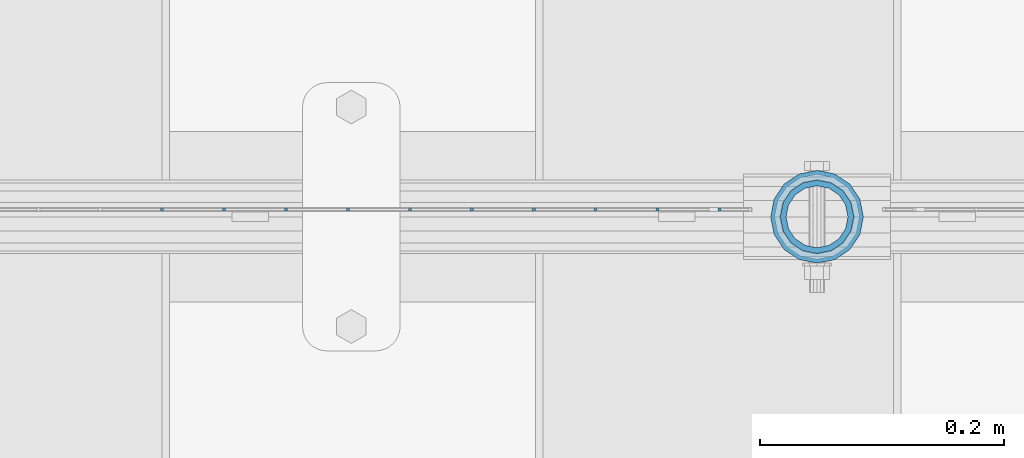
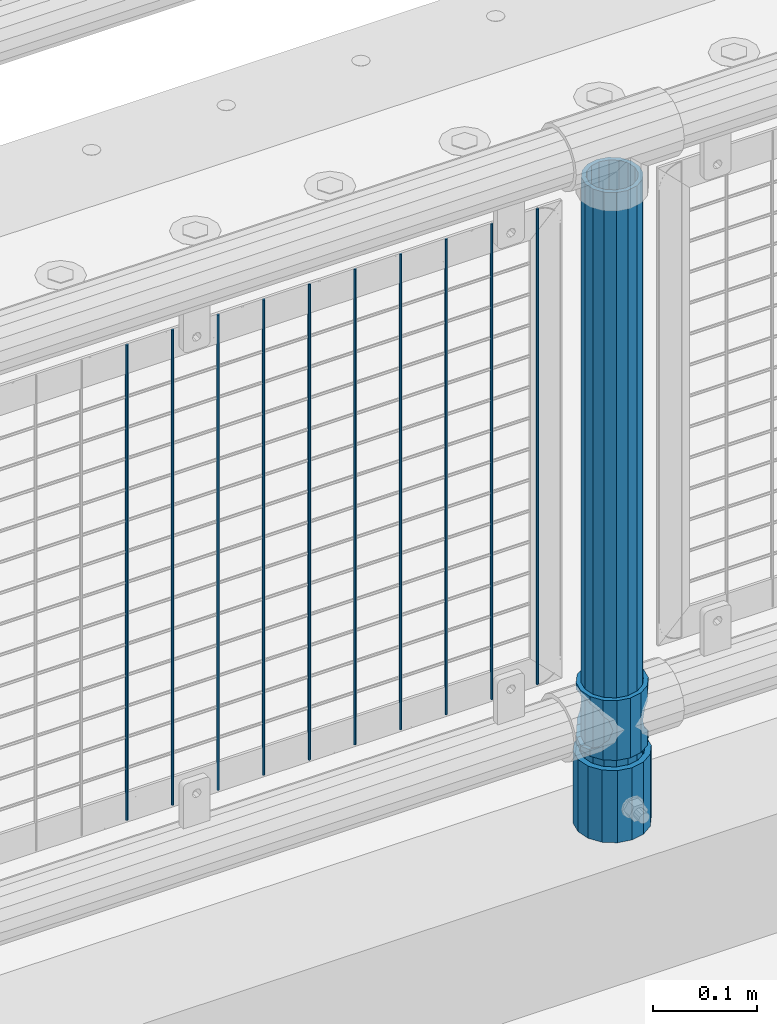
# One storey, part 103 of 270: 13 columns.
"""IFC2X3 building model written with IfcOpenShell, lengths in millimetres."""

from ifc_helpers import new_model, si_unit, frame, origin_with_axes, place, context, subcontext, project, spatial, faceted_brep, material, type_object, element, save


model = new_model("IFC2X3")

# Units and contexts
model_context = context("Model", 3, precision=1e-05, world=origin_with_axes())
body_context = subcontext(model_context, "Body", "Model", "MODEL_VIEW")
ifc_project = project(units=[si_unit("LENGTHUNIT", "METRE", prefix="MILLI"), si_unit("AREAUNIT", "SQUARE_METRE"), si_unit("VOLUMEUNIT", "CUBIC_METRE"), si_unit("MASSUNIT", "GRAM", prefix="KILO"), si_unit("TIMEUNIT", "SECOND"), si_unit("PLANEANGLEUNIT", "RADIAN"), si_unit("SOLIDANGLEUNIT", "STERADIAN"), si_unit("THERMODYNAMICTEMPERATUREUNIT", "DEGREE_CELSIUS"), si_unit("LUMINOUSINTENSITYUNIT", "LUMEN")], contexts=[model_context])

# Site, building, storey
site_placement = place(None, origin_with_axes())
site = spatial("IfcSite", under=ifc_project, at=site_placement, CompositionType="ELEMENT")
building_placement = place(site_placement, origin_with_axes())
building = spatial("IfcBuilding", under=site, at=building_placement, Name="Standard", CompositionType="ELEMENT")
storey_placement = place(building_placement, origin_with_axes())
storey = spatial("IfcBuildingStorey", under=building, at=storey_placement, Name="Undefined", CompositionType="ELEMENT", Elevation=0.0)

# Columns
ifc_material_1 = material()
column_type_1 = type_object("IfcColumnType", PredefinedType="NOTDEFINED")
column_1_placement = place(storey_placement, frame((16950.9999998042, -16335.5, 168.019999999998), z_axis=(-1.0, 0.0, 0.0), x_axis=(0.0, 0.0, 1.0)))
element("IfcColumn", 1, at=column_1_placement, inside=storey, type_object=column_type_1, material=ifc_material_1, context=body_context, shape_type="Brep", body=[
    faceted_brep([(0.0, -25.3500000000004, 0.0), (0.0, -23.4203461491616, 9.70102501045403), (760.0, -23.4203461491616, 9.70102501045403), (760.0, -25.3500000000004, 0.0), (0.0, -17.9251569030785, 17.9251569030785), (760.0, -17.9251569030785, 17.9251569030785), (0.0, -9.70102501045585, 23.4203461491597), (760.0, -9.70102501045585, 23.4203461491597), (0.0, 0.0, 25.3499999999985), (760.0, 0.0, 25.3499999999985), (0.0, 9.70102501045585, 23.4203461491597), (760.0, 9.70102501045585, 23.4203461491597), (0.0, 17.9251569030785, 17.9251569030785), (760.0, 17.9251569030785, 17.9251569030785), (0.0, 23.4203461491616, 9.70102501045403), (760.0, 23.4203461491616, 9.70102501045403), (0.0, 25.3500000000004, 0.0), (760.0, 25.3500000000004, 0.0), (0.0, 23.4203461491616, -9.70102501045403), (760.0, 23.4203461491616, -9.70102501045403), (0.0, 17.9251569030785, -17.9251569030785), (760.0, 17.9251569030785, -17.9251569030785), (0.0, 9.70102501045585, -23.4203461491597), (760.0, 9.70102501045585, -23.4203461491597), (0.0, 0.0, -25.3499999999985), (760.0, 0.0, -25.3499999999985), (0.0, -9.70102501045585, -23.4203461491597), (760.0, -9.70102501045585, -23.4203461491597), (0.0, -17.9251569030785, -17.9251569030785), (760.0, -17.9251569030785, -17.9251569030785), (0.0, -23.4203461491616, -9.70102501045403), (760.0, -23.4203461491616, -9.70102501045403), (0.0, -30.1499999999996, 0.0), (0.0, -27.8549679052157, -11.5379054858058), (760.0, -27.8549679052157, -11.5379054858058), (760.0, -30.1499999999996, 0.0), (0.0, -21.3192694527752, -21.3192694527752), (760.0, -21.3192694527752, -21.3192694527752), (0.0, -11.5379054858076, -27.8549679052157), (760.0, -11.5379054858076, -27.8549679052157), (0.0, 0.0, -30.1500000000015), (760.0, 0.0, -30.1500000000015), (0.0, 11.5379054858076, -27.8549679052157), (760.0, 11.5379054858076, -27.8549679052157), (0.0, 21.3192694527752, -21.3192694527752), (760.0, 21.3192694527752, -21.3192694527752), (0.0, 27.8549679052157, -11.5379054858058), (760.0, 27.8549679052157, -11.5379054858058), (0.0, 30.1499999999996, 0.0), (760.0, 30.1499999999996, 0.0), (0.0, 27.8549679052157, 11.5379054858058), (760.0, 27.8549679052157, 11.5379054858058), (0.0, 21.3192694527752, 21.3192694527752), (760.0, 21.3192694527752, 21.3192694527752), (0.0, 11.5379054858076, 27.8549679052157), (760.0, 11.5379054858076, 27.8549679052157), (0.0, 0.0, 30.1500000000015), (760.0, 0.0, 30.1500000000015), (0.0, -11.5379054858076, 27.8549679052157), (760.0, -11.5379054858076, 27.8549679052157), (0.0, -21.3192694527752, 21.3192694527752), (760.0, -21.3192694527752, 21.3192694527752), (0.0, -27.8549679052157, 11.5379054858058), (760.0, -27.8549679052157, 11.5379054858058)], [[[0, 1, 2, 3]], [[1, 4, 5, 2]], [[4, 6, 7, 5]], [[6, 8, 9, 7]], [[8, 10, 11, 9]], [[10, 12, 13, 11]], [[12, 14, 15, 13]], [[14, 16, 17, 15]], [[16, 18, 19, 17]], [[18, 20, 21, 19]], [[20, 22, 23, 21]], [[22, 24, 25, 23]], [[24, 26, 27, 25]], [[26, 28, 29, 27]], [[28, 30, 31, 29]], [[30, 0, 3, 31]], [[32, 33, 34, 35]], [[33, 36, 37, 34]], [[36, 38, 39, 37]], [[38, 40, 41, 39]], [[40, 42, 43, 41]], [[42, 44, 45, 43]], [[44, 46, 47, 45]], [[46, 48, 49, 47]], [[48, 50, 51, 49]], [[50, 52, 53, 51]], [[52, 54, 55, 53]], [[54, 56, 57, 55]], [[56, 58, 59, 57]], [[58, 60, 61, 59]], [[60, 62, 63, 61]], [[62, 32, 35, 63]], [[37, 39, 41, 43, 45, 47, 49, 51, 53, 55, 57, 59, 61, 63, 35, 34], [5, 7, 9, 11, 13, 15, 17, 19, 21, 23, 25, 27, 29, 31, 3, 2]], [[62, 60, 58, 56, 54, 52, 50, 48, 46, 44, 42, 40, 38, 36, 33, 32], [30, 28, 26, 24, 22, 20, 18, 16, 14, 12, 10, 8, 6, 4, 1, 0]]]),
])
column_type_2 = type_object("IfcColumnType", PredefinedType="NOTDEFINED")
column_2_placement = place(storey_placement, frame((16950.9999998042, -16335.5, 168.019999999998), z_axis=(0.0, 1.0, 0.0), x_axis=(0.0, 0.0, 1.0)))
element("IfcColumn", 2, at=column_2_placement, inside=storey, type_object=column_type_2, material=ifc_material_1, context=body_context, shape_type="Brep", body=[
    faceted_brep([(0.0, -31.75, 0.0), (0.0, -29.3331751572332, 12.1501989775916), (85.0, -29.3331751572332, 12.1501989775916), (85.0, -31.75, 0.0), (0.0, -22.4506403026717, 22.4506403026735), (85.0, -22.4506403026717, 22.4506403026735), (0.0, -12.1501989775934, 29.3331751572332), (85.0, -12.1501989775934, 29.3331751572332), (0.0, 0.0, 31.75), (85.0, 0.0, 31.75), (0.0, 12.1501989775934, 29.3331751572332), (85.0, 12.1501989775934, 29.3331751572332), (0.0, 22.4506403026717, 22.4506403026735), (85.0, 22.4506403026717, 22.4506403026735), (0.0, 29.3331751572332, 12.1501989775916), (85.0, 29.3331751572332, 12.1501989775916), (0.0, 31.75, 0.0), (85.0, 31.75, 0.0), (0.0, 29.3331751572332, -12.1501989775916), (85.0, 29.3331751572332, -12.1501989775916), (0.0, 22.4506403026717, -22.4506403026735), (85.0, 22.4506403026717, -22.4506403026735), (0.0, 12.1501989775934, -29.3331751572332), (85.0, 12.1501989775934, -29.3331751572332), (0.0, 0.0, -31.75), (85.0, 0.0, -31.75), (0.0, -12.1501989775934, -29.3331751572332), (85.0, -12.1501989775934, -29.3331751572332), (0.0, -22.4506403026717, -22.4506403026735), (85.0, -22.4506403026717, -22.4506403026735), (0.0, -29.3331751572332, -12.1501989775916), (85.0, -29.3331751572332, -12.1501989775916), (0.0, -38.0499999999993, 0.0), (0.0, -35.1536162120537, -14.561104601491), (85.0, -35.1536162120537, -14.561104601491), (85.0, -38.0499999999993, 0.0), (0.0, -26.9054130241493, -26.9054130241475), (85.0, -26.9054130241493, -26.9054130241475), (0.0, -14.5611046014928, -35.1536162120537), (85.0, -14.5611046014928, -35.1536162120537), (0.0, 0.0, -38.0499999999993), (85.0, 0.0, -38.0499999999993), (0.0, 14.5611046014928, -35.1536162120537), (85.0, 14.5611046014928, -35.1536162120537), (0.0, 26.9054130241493, -26.9054130241475), (85.0, 26.9054130241493, -26.9054130241475), (0.0, 35.1536162120537, -14.561104601491), (85.0, 35.1536162120537, -14.561104601491), (0.0, 38.0499999999993, 0.0), (85.0, 38.0499999999993, 0.0), (0.0, 35.1536162120537, 14.561104601491), (85.0, 35.1536162120537, 14.561104601491), (0.0, 26.9054130241493, 26.9054130241475), (85.0, 26.9054130241493, 26.9054130241475), (0.0, 14.5611046014928, 35.1536162120537), (85.0, 14.5611046014928, 35.1536162120537), (0.0, 0.0, 38.0499999999993), (85.0, 0.0, 38.0499999999993), (0.0, -14.5611046014928, 35.1536162120537), (85.0, -14.5611046014928, 35.1536162120537), (0.0, -26.9054130241493, 26.9054130241475), (85.0, -26.9054130241493, 26.9054130241475), (0.0, -35.1536162120537, 14.561104601491), (85.0, -35.1536162120537, 14.561104601491)], [[[0, 1, 2, 3]], [[1, 4, 5, 2]], [[4, 6, 7, 5]], [[6, 8, 9, 7]], [[8, 10, 11, 9]], [[10, 12, 13, 11]], [[12, 14, 15, 13]], [[14, 16, 17, 15]], [[16, 18, 19, 17]], [[18, 20, 21, 19]], [[20, 22, 23, 21]], [[22, 24, 25, 23]], [[24, 26, 27, 25]], [[26, 28, 29, 27]], [[28, 30, 31, 29]], [[30, 0, 3, 31]], [[32, 33, 34, 35]], [[33, 36, 37, 34]], [[36, 38, 39, 37]], [[38, 40, 41, 39]], [[40, 42, 43, 41]], [[42, 44, 45, 43]], [[44, 46, 47, 45]], [[46, 48, 49, 47]], [[48, 50, 51, 49]], [[50, 52, 53, 51]], [[52, 54, 55, 53]], [[54, 56, 57, 55]], [[56, 58, 59, 57]], [[58, 60, 61, 59]], [[60, 62, 63, 61]], [[62, 32, 35, 63]], [[37, 39, 41, 43, 45, 47, 49, 51, 53, 55, 57, 59, 61, 63, 35, 34], [5, 7, 9, 11, 13, 15, 17, 19, 21, 23, 25, 27, 29, 31, 3, 2]], [[62, 60, 58, 56, 54, 52, 50, 48, 46, 44, 42, 40, 38, 36, 33, 32], [30, 28, 26, 24, 22, 20, 18, 16, 14, 12, 10, 8, 6, 4, 1, 0]]]),
])
ifc_material_2 = material(Name="Misc_Undefined")
column_type_3 = type_object("IfcColumnType", PredefinedType="NOTDEFINED")
column_3_placement = place(storey_placement, frame((16951.0, -16335.5, 263.02), z_axis=(-1.0, 0.0, 0.0), x_axis=(0.0, 0.0, 1.0)))
element("IfcColumn", 3, at=column_3_placement, inside=storey, type_object=column_type_3, material=ifc_material_2, context=body_context, shape_type="Brep", body=[
    faceted_brep([(63.1897438117183, 11.6144421722802, -32.8397438117208), (63.1897438117183, 11.6144421722802, -28.0397438117179), (56.6106908090125, 21.4606908090118, -21.46069080901), (56.6106908090125, 21.4606908090118, -27.1226768591005), (61.9623795176767, 13.4513226476338, -32.4743655677703), (46.7644421722812, 28.0397438117179, -11.614442172282), (46.7644421722812, 28.0397438117179, -20.0882031229812), (51.5310424080071, 24.8548033587067, -24.8548033587067), (35.1500000000015, 30.35, 0.0), (35.1500000000008, 30.3500000000004, -16.6306603983612), (23.5355578277203, 28.0397438117179, -11.614442172282), (23.5355578277203, 28.0397438117179, -20.0882031229812), (18.7689575919954, 24.8548033587067, -24.8548033587067), (13.689309190989, 21.4606908090118, -21.46069080901), (13.689309190989, 21.4606908090118, -27.1226768591005), (8.33762048232484, 13.4513226476338, -32.4743655677703), (7.11025618828324, 11.6144421722802, -28.0397438117179), (7.11025618828324, 11.6144421722802, -32.8397438117208), (4.80000000000075, 0.0, -30.3499999999985), (4.80000000000075, 0.0, -35.1500000000015), (7.11025618828319, -11.6144421722802, -28.0397438117179), (7.11025618828319, -11.6144421722802, -32.8397438117172), (13.689309190989, -21.4606908090118, -21.46069080901), (13.689309190989, -21.4606908090118, -27.1226768591041), (8.33762048232484, -13.4513226476338, -32.4743655677703), (23.5355578277203, -28.0397438117179, -11.614442172282), (23.5355578277203, -28.0397438117179, -20.0882031229885), (18.7689575919954, -24.8548033587067, -24.8548033587067), (35.1500000000015, -30.35, 0.0), (35.1500000000008, -30.3500000000004, -16.6306603983721), (46.7644421722812, -28.0397438117179, -11.614442172282), (46.7644421722812, -28.0397438117179, -20.0882031229885), (51.5310424080071, -24.8548033587067, -24.8548033587067), (56.6106908090125, -21.4606908090118, -21.46069080901), (56.6106908090125, -21.4606908090118, -27.1226768591041), (61.9623795176767, -13.4513226476338, -32.4743655677703), (63.1897438117183, -11.6144421722802, -28.0397438117179), (63.1897438117183, -11.6144421722802, -32.8397438117172), (65.5000000000008, 0.0, -30.3499999999985), (65.5000000000008, 0.0, -35.1500000000015), (0.0, -28.0397438117179, -11.614442172282), (0.0, -30.3500000000004, 0.0), (0.0, -21.4606908090118, -21.46069080901), (0.0, -11.6144421722802, -28.0397438117179), (0.0, 0.0, -30.3499999999985), (0.0, 11.6144421722802, -28.0397438117179), (0.0, 21.4606908090118, -21.46069080901), (0.0, 28.0397438117179, -11.614442172282), (0.0, 30.3500000000004, 0.0), (0.0, 28.0397438117179, 11.614442172282), (23.5355578277192, 28.0397438117179, 11.614442172282), (0.0, 21.4606908090118, 21.46069080901), (13.6893091909879, 21.4606908090118, 21.46069080901), (0.0, 11.6144421722802, 28.0397438117179), (7.11025618828211, 11.6144421722802, 28.0397438117179), (0.0, 0.0, 30.3499999999985), (4.79999999999961, 0.0, 30.3499999999985), (0.0, -11.6144421722802, 28.0397438117179), (7.11025618828205, -11.6144421722802, 28.0397438117179), (0.0, -21.4606908090118, 21.46069080901), (13.6893091909879, -21.4606908090118, 21.46069080901), (0.0, -28.0397438117179, 11.614442172282), (23.5355578277191, -28.0397438117179, 11.614442172282), (0.0, -32.4743655677721, 13.4513226476338), (0.0, -35.1499999999996, 0.0), (70.2999999999993, -35.1499999999996, 0.0), (70.2999999999993, -32.4743655677721, 13.4513226476338), (0.0, 13.4513226476338, -32.4743655677703), (0.0, 24.8548033587067, -24.8548033587067), (0.0, 0.0, -35.1499999999996), (0.0, -13.4513226476338, -32.4743655677703), (0.0, -24.8548033587067, -24.8548033587067), (0.0, -24.8548033587067, 24.8548033587067), (0.0, -13.4513226476338, 32.4743655677703), (0.0, 0.0, 35.1499999999996), (0.0, 13.4513226476338, 32.4743655677703), (0.0, 24.8548033587067, 24.8548033587067), (0.0, 32.4743655677721, 13.4513226476338), (0.0, 35.1499999999996, 0.0), (0.0, 32.4743655677721, -13.4513226476338), (0.0, -32.4743655677721, -13.4513226476338), (70.2999999999993, 32.4743655677721, 13.4513226476338), (70.2999999999993, 35.1499999999996, 0.0), (70.2999999999993, 32.4743655677721, -13.4513226476338), (70.2999999999993, 24.8548033587067, -24.8548033587067), (70.2999999999993, 13.4513226476338, -32.4743655677703), (70.2999999999993, 0.0, -35.1500000000015), (70.2999999999993, -13.4513226476338, -32.4743655677703), (70.2999999999993, -24.8548033587067, -24.8548033587067), (70.2999999999993, -32.4743655677721, -13.4513226476338), (70.2999999999993, 28.0397438117179, 11.614442172282), (70.2999999999993, 21.4606908090118, 21.46069080901), (56.6106908090114, 21.4606908090118, 21.46069080901), (46.7644421722801, 28.0397438117179, 11.614442172282), (70.2999999999993, 11.6144421722802, 28.0397438117179), (63.1897438117172, 11.6144421722802, 28.0397438117179), (70.2999999999993, 0.0, 30.3499999999985), (65.4999999999997, 0.0, 30.3499999999985), (70.2999999999993, -11.6144421722802, 28.0397438117179), (63.1897438117172, -11.6144421722802, 28.0397438117179), (70.2999999999993, -21.4606908090118, 21.46069080901), (56.6106908090114, -21.4606908090118, 21.46069080901), (70.2999999999993, -28.0397438117179, 11.614442172282), (46.7644421722801, -28.0397438117179, 11.614442172282), (70.2999999999993, -11.6144421722802, -28.0397438117179), (70.2999999999993, 0.0, -30.3499999999985), (70.2999999999993, -21.4606908090118, -21.46069080901), (70.2999999999993, -28.0397438117179, -11.614442172282), (70.2999999999993, -30.3500000000004, 0.0), (70.2999999999993, 24.8548033587067, 24.8548033587067), (70.2999999999993, 13.4513226476338, 32.4743655677703), (70.2999999999993, 0.0, 35.1500000000015), (70.2999999999993, -13.4513226476338, 32.4743655677703), (70.2999999999993, -24.8548033587067, 24.8548033587067), (70.2999999999993, 30.3500000000004, 0.0), (70.2999999999993, 28.0397438117179, -11.614442172282), (70.2999999999993, 21.4606908090118, -21.46069080901), (70.2999999999993, 11.6144421722802, -28.0397438117179), (61.9623795176767, 13.4513226476338, 32.4743655677703), (51.5310424080039, 24.8548033587067, 24.8548033587067), (56.6106908090114, 21.4606908090118, 27.1226768591041), (65.4999999999997, 0.0, 35.1500000000015), (63.1897438117172, 11.6144421722802, 32.8397438117172), (63.1897438117172, -11.6144421722802, 32.8397438117172), (61.9623795176767, -13.4513226476338, 32.4743655677703), (56.6106908090114, -21.4606908090118, 27.1226768591077), (51.5310424080071, -24.8548033587067, 24.8548033587067), (18.7689575919954, -24.8548033587067, 24.8548033587067), (46.7644421722801, -28.0397438117179, 20.0882031229849), (35.1499999999996, -30.3500000000004, 16.6306603983649), (23.5355578277191, -28.0397438117179, 20.0882031229849), (8.33762048232262, -13.4513226476338, 32.4743655677703), (13.6893091909879, -21.4606908090118, 27.1226768591077), (4.79999999999961, 0.0, 35.1500000000015), (7.11025618828205, -11.6144421722802, 32.8397438117172), (7.11025618828211, 11.6144421722802, 32.8397438117172), (8.33762048232262, 13.4513226476338, 32.4743655677703), (13.6893091909879, 21.4606908090118, 27.1226768591041), (18.7689575919954, 24.8548033587067, 24.8548033587067), (23.5355578277192, 28.0397438117179, 20.0882031229885), (35.1499999999996, 30.3500000000004, 16.6306603983685), (46.7644421722801, 28.0397438117179, 20.0882031229885)], [[[0, 1, 2, 3, 4]], [[3, 2, 5, 6, 7]], [[6, 5, 8, 9]], [[9, 8, 10, 11]], [[12, 11, 10, 13, 14]], [[15, 14, 13, 16, 17]], [[17, 16, 18, 19]], [[19, 18, 20, 21]], [[21, 20, 22, 23, 24]], [[23, 22, 25, 26, 27]], [[26, 25, 28, 29]], [[29, 28, 30, 31]], [[32, 31, 30, 33, 34]], [[35, 34, 33, 36, 37]], [[37, 36, 38, 39]], [[39, 38, 1, 0]], [[40, 41, 28, 25]], [[42, 40, 25, 22]], [[43, 42, 22, 20]], [[44, 43, 20, 18]], [[45, 44, 18, 16]], [[46, 45, 16, 13]], [[47, 46, 13, 10]], [[48, 47, 10, 8]], [[49, 48, 8, 50]], [[51, 49, 50, 52]], [[53, 51, 52, 54]], [[55, 53, 54, 56]], [[57, 55, 56, 58]], [[59, 57, 58, 60]], [[61, 59, 60, 62]], [[41, 61, 62, 28]], [[63, 64, 65, 66]], [[67, 68, 12, 14, 15]], [[69, 67, 15, 17, 19]], [[24, 70, 69, 19, 21]], [[27, 71, 70, 24, 23]], [[63, 72, 73, 74, 75, 76, 77, 78, 79, 68, 67, 69, 70, 71, 80, 64], [40, 42, 43, 44, 45, 46, 47, 48, 49, 51, 53, 55, 57, 59, 61, 41]], [[78, 77, 81, 82]], [[79, 78, 82, 83]], [[68, 79, 83, 84, 7, 6, 9, 11, 12]], [[7, 84, 85, 4, 3]], [[4, 85, 86, 39, 0]], [[87, 88, 32, 34, 35]], [[86, 87, 35, 37, 39]], [[29, 31, 32, 88, 89, 80, 71, 27, 26]], [[64, 80, 89, 65]], [[90, 91, 92, 93]], [[91, 94, 95, 92]], [[94, 96, 97, 95]], [[96, 98, 99, 97]], [[98, 100, 101, 99]], [[100, 102, 103, 101]], [[104, 105, 38, 36]], [[106, 104, 36, 33]], [[107, 106, 33, 30]], [[108, 107, 30, 28]], [[102, 108, 28, 103]], [[88, 87, 86, 85, 84, 83, 82, 81, 109, 110, 111, 112, 113, 66, 65, 89], [100, 98, 96, 94, 91, 90, 114, 115, 116, 117, 105, 104, 106, 107, 108, 102]], [[118, 110, 109, 119, 120]], [[121, 111, 110, 118, 122]], [[112, 111, 121, 123, 124]], [[113, 112, 124, 125, 126]], [[127, 72, 63, 66, 113, 126, 128, 129, 130]], [[131, 73, 72, 127, 132]], [[133, 74, 73, 131, 134]], [[75, 74, 133, 135, 136]], [[76, 75, 136, 137, 138]], [[119, 109, 81, 77, 76, 138, 139, 140, 141]], [[92, 120, 119, 141, 93]], [[95, 122, 118, 120, 92]], [[97, 121, 122, 95]], [[99, 123, 121, 97]], [[101, 125, 124, 123, 99]], [[103, 128, 126, 125, 101]], [[28, 129, 128, 103]], [[62, 130, 129, 28]], [[60, 132, 127, 130, 62]], [[58, 134, 131, 132, 60]], [[56, 133, 134, 58]], [[54, 135, 133, 56]], [[52, 137, 136, 135, 54]], [[50, 139, 138, 137, 52]], [[8, 140, 139, 50]], [[93, 141, 140, 8]], [[114, 90, 93, 8]], [[115, 114, 8, 5]], [[116, 115, 5, 2]], [[117, 116, 2, 1]], [[105, 117, 1, 38]]]),
])
column_type_4 = type_object("IfcColumnType", Name="D3", PredefinedType="NOTDEFINED")
for number, where, z_axis, x_axis in (
    (4, (16820.204, -16329.5, 353.02), (-1.0, 0.0, 0.0), (0.0, 0.0, 1.0)),
    (5, (16769.411, -16329.5, 353.02), (-1.0, 0.0, 0.0), (0.0, 0.0, 1.0)),
    (6, (16718.618, -16329.5, 353.02), (-1.0, 0.0, 0.0), (0.0, 0.0, 1.0)),
    (7, (16667.825, -16329.5, 353.02), (-1.0, 0.0, 0.0), (0.0, 0.0, 1.0)),
    (8, (16617.032, -16329.5, 353.02), (-1.0, 0.0, 0.0), (0.0, 0.0, 1.0)),
    (9, (16566.239, -16329.5, 353.02), (-1.0, 0.0, 0.0), (0.0, 0.0, 1.0)),
    (10, (16515.446, -16329.5, 353.02), (-1.0, 0.0, 0.0), (0.0, 0.0, 1.0)),
    (11, (16870.997, -16329.5, 353.02), (-1.0, 0.0, 0.0), (0.0, 0.0, 1.0)),
    (12, (16464.653, -16329.5, 353.02), (-1.0, 0.0, 0.0), (0.0, 0.0, 1.0)),
    (13, (16413.86, -16329.5, 353.02), (-1.0, 0.0, 0.0), (0.0, 0.0, 1.0)),
):
    element("IfcColumn", number, at=place(storey_placement, frame(where, z_axis=z_axis, x_axis=x_axis)), inside=storey, type_object=column_type_4, material=ifc_material_2, ObjectType="D3", context=body_context, shape_type="Brep", body=[
        faceted_brep([(0.0, -1.5, 0.0), (0.0, -0.75, -1.29903810567669), (560.0, -0.75, -1.29903810567703), (560.0, -1.5, 0.0), (0.0, 0.75, -1.29903810567669), (560.0, 0.75, -1.29903810567703), (0.0, 1.5, 0.0), (560.0, 1.5, 0.0), (0.0, 0.75, 1.29903810567669), (560.0, 0.75, 1.29903810567703), (0.0, -0.75, 1.29903810567669), (560.0, -0.75, 1.29903810567703)], [[[0, 1, 2, 3]], [[1, 4, 5, 2]], [[4, 6, 7, 5]], [[6, 8, 9, 7]], [[8, 10, 11, 9]], [[10, 0, 3, 11]], [[5, 7, 9, 11, 3, 2]], [[10, 8, 6, 4, 1, 0]]]),
    ])

save(model, "model.ifc")
